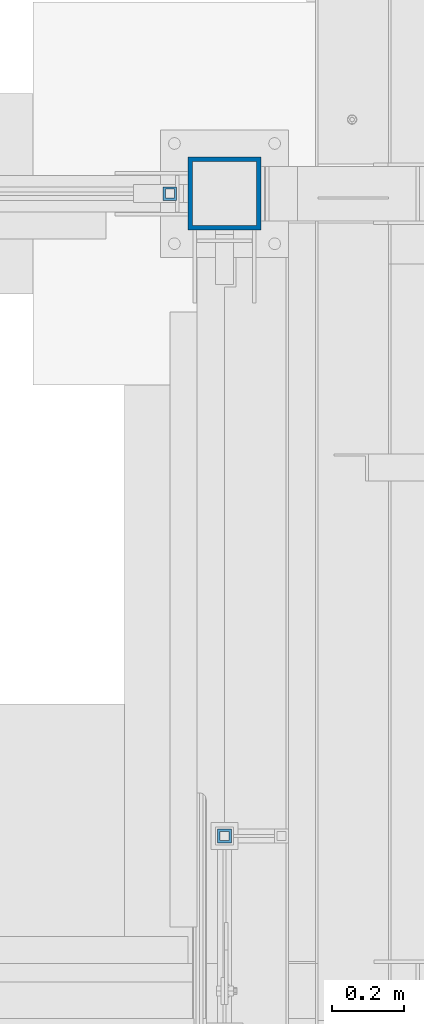
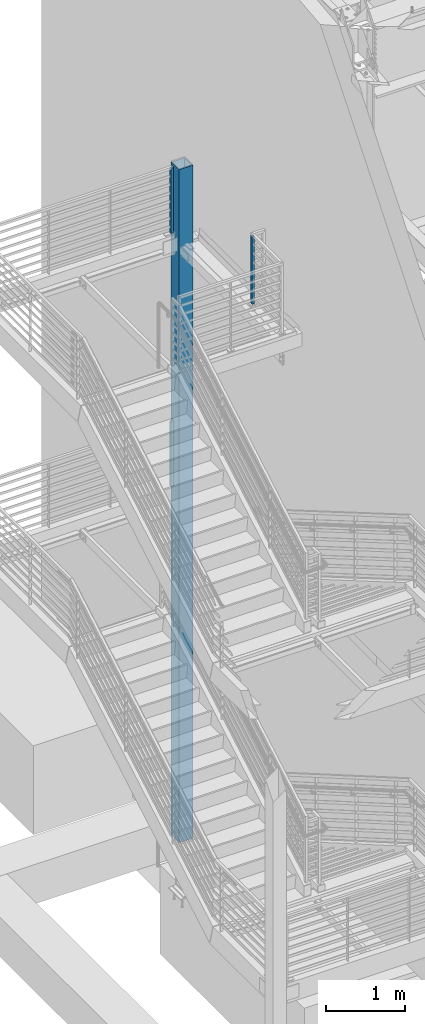
# One storey, part 367 of 1179: 4 columns, 4 elements without a shape of their own.
"""IFC2X3 building model written with IfcOpenShell, lengths in millimetres."""

from ifc_helpers import new_model, si_unit, frame, origin_with_axes, place, context, subcontext, project, spatial, faceted_brep, material, type_object, element, aggregate, save


model = new_model("IFC2X3")

# Units and contexts
model_context = context("Model", 3, precision=1e-05, world=origin_with_axes())
body_context = subcontext(model_context, "Body", "Model", "MODEL_VIEW")
ifc_project = project(units=[si_unit("LENGTHUNIT", "METRE", prefix="MILLI"), si_unit("AREAUNIT", "SQUARE_METRE"), si_unit("VOLUMEUNIT", "CUBIC_METRE"), si_unit("MASSUNIT", "GRAM", prefix="KILO"), si_unit("TIMEUNIT", "SECOND"), si_unit("PLANEANGLEUNIT", "RADIAN"), si_unit("SOLIDANGLEUNIT", "STERADIAN"), si_unit("THERMODYNAMICTEMPERATUREUNIT", "DEGREE_CELSIUS"), si_unit("LUMINOUSINTENSITYUNIT", "LUMEN")], contexts=[model_context])

# Site, building, storey
site_placement = place(None, origin_with_axes())
site = spatial("IfcSite", under=ifc_project, at=site_placement, CompositionType="ELEMENT")
building_placement = place(site_placement, origin_with_axes())
building = spatial("IfcBuilding", under=site, at=building_placement, Name="Undefined", CompositionType="ELEMENT")
storey_placement = place(building_placement, origin_with_axes())
storey = spatial("IfcBuildingStorey", under=building, at=storey_placement, Name="Undefined", CompositionType="ELEMENT", Elevation=0.0)

# Assembly, column
assembly_1_placement = place(storey_placement, origin_with_axes())
assembly_1 = element("IfcElementAssembly", 1, at=assembly_1_placement, inside=storey, Name="GUARDRAIL", AssemblyPlace="NOTDEFINED", PredefinedType="RIGID_FRAME")
ifc_material = material()
column_type_1 = type_object("IfcColumnType", Name="HSS1-1/2X1-1/2X1/4", PredefinedType="NOTDEFINED")
column_1_placement = place(assembly_1_placement, frame((-406.4, 37642.8, 8210.55), z_axis=(-1.0, 0.0, 0.0), x_axis=(0.0, 0.0, 1.0)))
column_1 = element("IfcColumn", 2, at=column_1_placement, type_object=column_type_1, material=ifc_material, Name="POST", ObjectType="HSS1-1/2X1-1/2X1/4", context=body_context, shape_type="Brep", body=[
    faceted_brep([(2.27373675443232e-13, 12.6999993300487, -12.6999993299996), (-6.82121026329696e-13, -12.6999993300415, -12.6999993299996), (1016.05291868232, -12.6999993299978, -12.69999933), (1016.05291868232, 12.6999993299978, -12.69999933), (-6.82121026329696e-13, -12.6999993300415, 12.6999993299996), (990.652920022321, -12.6999993299978, 12.69999933), (2.27373675443232e-13, 12.6999993300487, 12.6999993299996), (990.652920022321, 12.6999993299978, 12.69999933), (0.0, 19.0499992350015, -19.0499992349996), (0.0, 19.0499992350015, 19.0499992349996), (984.302920117321, 19.0499992350015, 19.049999235), (1022.40291858732, 19.0499992350015, -19.049999235), (0.0, -19.0499992350015, 19.0499992349996), (984.302920117321, -19.0499992350015, 19.049999235), (0.0, -19.0499992350015, -19.0499992349996), (1022.40291858732, -19.0499992350015, -19.049999235)], [[[0, 1, 2, 3]], [[1, 4, 5, 2]], [[4, 6, 7, 5]], [[6, 0, 3, 7]], [[8, 9, 10, 11]], [[9, 12, 13, 10]], [[12, 14, 15, 13]], [[14, 8, 11, 15]], [[13, 15, 11, 10], [5, 7, 3, 2]], [[14, 12, 9, 8], [6, 4, 1, 0]]]),
])
aggregate(assembly_1, [column_1])

assembly_2_placement = place(storey_placement, origin_with_axes())
assembly_2 = element("IfcElementAssembly", 3, at=assembly_2_placement, inside=storey, Name="GUARDRAIL", AssemblyPlace="NOTDEFINED", PredefinedType="RIGID_FRAME")
column_2_placement = place(assembly_2_placement, frame((-254.000004638121, 35852.100000607, 8147.05), z_axis=(-1.0, 0.0, 0.0), x_axis=(0.0, 0.0, 1.0)))
column_2 = element("IfcColumn", 4, at=column_2_placement, type_object=column_type_1, material=ifc_material, Name="POST", ObjectType="HSS1-1/2X1-1/2X1/4", context=body_context, shape_type="Brep", body=[
    faceted_brep([(2.27373675443232e-13, 12.6999993300487, -12.6999993299996), (-6.82121026329696e-13, -12.6999993300415, -12.6999993299996), (1047.74814416957, -12.6999993299978, -12.69999933), (1047.74814414417, 12.6999993299978, -12.69999933), (-6.82121026329696e-13, -12.6999993300415, 12.6999993299996), (1047.74814416957, -12.6999993299978, 12.69999933), (2.27373675443232e-13, 12.6999993300487, 12.6999993299996), (1047.74814414417, 12.6999993299978, 12.69999933), (0.0, 19.0499992350015, -19.0499992349996), (0.0, 19.0499992350015, 19.0499992349996), (1047.74814413782, 19.0499992350015, 19.049999235), (1047.74814413782, 19.0499992350015, -19.049999235), (0.0, -19.0499992350015, 19.0499992349996), (1047.74814417592, -19.0499992350015, 19.049999235), (0.0, -19.0499992350015, -19.0499992349996), (1047.74814417592, -19.0499992350015, -19.049999235)], [[[0, 1, 2, 3]], [[1, 4, 5, 2]], [[4, 6, 7, 5]], [[6, 0, 3, 7]], [[8, 9, 10, 11]], [[9, 12, 13, 10]], [[12, 14, 15, 13]], [[14, 8, 11, 15]], [[13, 15, 11, 10], [5, 7, 3, 2]], [[14, 12, 9, 8], [6, 4, 1, 0]]]),
])
aggregate(assembly_2, [column_2])

assembly_3_placement = place(storey_placement, origin_with_axes())
assembly_3 = element("IfcElementAssembly", 5, at=assembly_3_placement, inside=storey, Name="GUARDRAIL", AssemblyPlace="NOTDEFINED", PredefinedType="RIGID_FRAME")
column_3_placement = place(assembly_3_placement, frame((-406.4, 37642.8, 4298.94999968978), z_axis=(-1.0, 0.0, 0.0), x_axis=(0.0, 0.0, 1.0)))
column_3 = element("IfcColumn", 6, at=column_3_placement, type_object=column_type_1, material=ifc_material, Name="POST", ObjectType="HSS1-1/2X1-1/2X1/4", context=body_context, shape_type="Brep", body=[
    faceted_brep([(2.27373675443232e-13, 12.6999993300487, -12.6999993299996), (-6.82121026329696e-13, -12.6999993300415, -12.6999993299996), (1016.05291868232, -12.6999993299978, -12.69999933), (1016.05291868232, 12.6999993299978, -12.69999933), (-6.82121026329696e-13, -12.6999993300415, 12.6999993299996), (990.652920022321, -12.6999993299978, 12.69999933), (2.27373675443232e-13, 12.6999993300487, 12.6999993299996), (990.652920022321, 12.6999993299978, 12.69999933), (0.0, 19.0499992350015, -19.0499992349996), (0.0, 19.0499992350015, 19.0499992349996), (984.302920117321, 19.0499992350015, 19.049999235), (1022.40291858732, 19.0499992350015, -19.049999235), (0.0, -19.0499992350015, 19.0499992349996), (984.302920117321, -19.0499992350015, 19.049999235), (0.0, -19.0499992350015, -19.0499992349996), (1022.40291858732, -19.0499992350015, -19.049999235)], [[[0, 1, 2, 3]], [[1, 4, 5, 2]], [[4, 6, 7, 5]], [[6, 0, 3, 7]], [[8, 9, 10, 11]], [[9, 12, 13, 10]], [[12, 14, 15, 13]], [[14, 8, 11, 15]], [[13, 15, 11, 10], [5, 7, 3, 2]], [[14, 12, 9, 8], [6, 4, 1, 0]]]),
])
aggregate(assembly_3, [column_3])

assembly_4_placement = place(storey_placement, origin_with_axes())
assembly_4 = element("IfcElementAssembly", 7, at=assembly_4_placement, inside=storey, Name="COLUMN", AssemblyPlace="NOTDEFINED", PredefinedType="RIGID_FRAME")
column_type_2 = type_object("IfcColumnType", Name="HSS8X8X1/2", PredefinedType="NOTDEFINED")
column_4_placement = place(assembly_4_placement, frame((-254.0, 37642.8, -1244.6), z_axis=(0.0, 1.0, 0.0), x_axis=(0.0, 0.0, 1.0)))
column_4 = element("IfcColumn", 8, at=column_4_placement, type_object=column_type_2, material=ifc_material, Name="COLUMN", ObjectType="HSS8X8X1/2", context=body_context, shape_type="Brep", body=[
    faceted_brep([(63.5, 88.9, -88.9000000000015), (63.5, -88.9, -88.9000000000015), (10467.975, -88.9, -88.9000000000015), (10467.975, 88.9, -88.9000000000015), (63.5, -88.9, 88.9000000000015), (10467.975, -88.9, 88.9000000000015), (63.5, 88.9, 88.9000000000015), (10467.975, 88.9, 88.9000000000015), (63.5, 101.6, -101.599999999999), (63.5, 101.6, 101.599999999999), (10467.975, 101.6, 101.599999999999), (10467.975, 101.6, -101.599999999999), (63.5, -101.6, 101.599999999999), (10467.975, -101.6, 101.599999999999), (63.5, -101.6, -101.599999999999), (10467.975, -101.6, -101.599999999999)], [[[0, 1, 2, 3]], [[1, 4, 5, 2]], [[4, 6, 7, 5]], [[6, 0, 3, 7]], [[8, 9, 10, 11]], [[9, 12, 13, 10]], [[12, 14, 15, 13]], [[14, 8, 11, 15]], [[13, 15, 11, 10], [5, 7, 3, 2]], [[14, 12, 9, 8], [6, 4, 1, 0]]]),
])
aggregate(assembly_4, [column_4])

save(model, "model.ifc")
